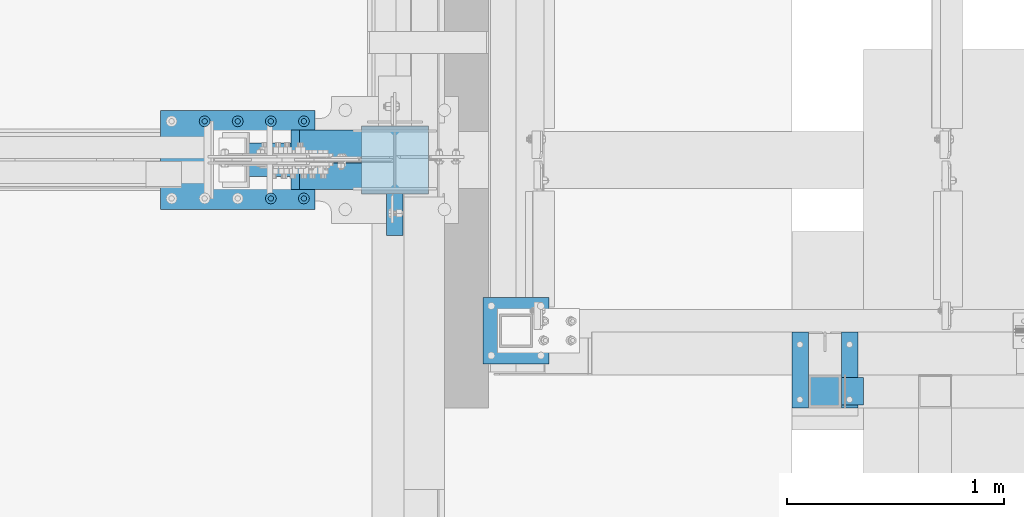
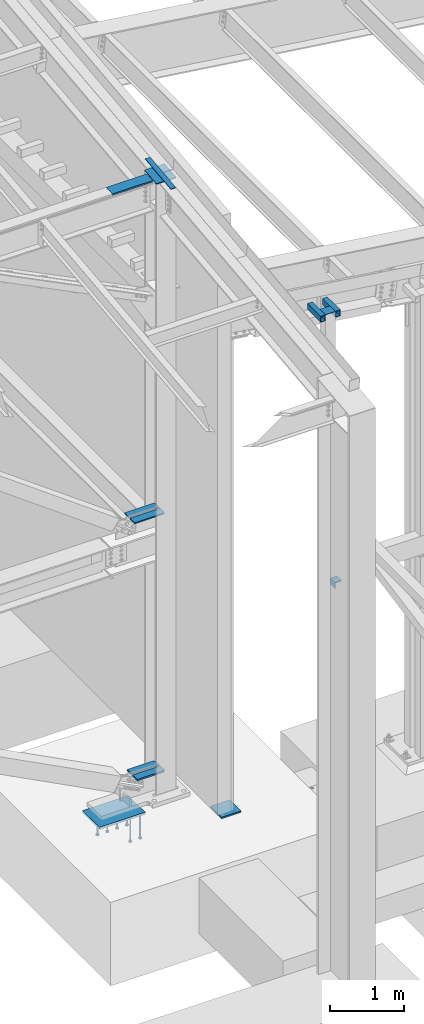
# One storey, part 819 of 1179: 19 beams, 10 elements without a shape of their own.
"""IFC2X3 building model written with IfcOpenShell, lengths in millimetres."""

from ifc_helpers import new_model, si_unit, frame, origin_with_axes, place, context, subcontext, project, spatial, faceted_brep, material, type_object, element, aggregate, save


model = new_model("IFC2X3")

# Units and contexts
model_context = context("Model", 3, precision=1e-05, world=origin_with_axes())
body_context = subcontext(model_context, "Body", "Model", "MODEL_VIEW")
ifc_project = project(units=[si_unit("LENGTHUNIT", "METRE", prefix="MILLI"), si_unit("AREAUNIT", "SQUARE_METRE"), si_unit("VOLUMEUNIT", "CUBIC_METRE"), si_unit("MASSUNIT", "GRAM", prefix="KILO"), si_unit("TIMEUNIT", "SECOND"), si_unit("PLANEANGLEUNIT", "RADIAN"), si_unit("SOLIDANGLEUNIT", "STERADIAN"), si_unit("THERMODYNAMICTEMPERATUREUNIT", "DEGREE_CELSIUS"), si_unit("LUMINOUSINTENSITYUNIT", "LUMEN")], contexts=[model_context])

# Site, building, storey
site_placement = place(None, origin_with_axes())
site = spatial("IfcSite", under=ifc_project, at=site_placement, CompositionType="ELEMENT")
building_placement = place(site_placement, origin_with_axes())
building = spatial("IfcBuilding", under=site, at=building_placement, Name="Undefined", CompositionType="ELEMENT")
storey_placement = place(building_placement, origin_with_axes())
storey = spatial("IfcBuildingStorey", under=building, at=storey_placement, Name="Undefined", CompositionType="ELEMENT", Elevation=0.0)

# Assembly, beam
assembly_1_placement = place(storey_placement, origin_with_axes())
assembly_1 = element("IfcElementAssembly", 1, at=assembly_1_placement, inside=storey, Name="BEAM", AssemblyPlace="NOTDEFINED", PredefinedType="RIGID_FRAME")
ifc_material_1 = material(Name="STEEL/A36")
beam_type_1 = type_object("IfcBeamType", PredefinedType="NOTDEFINED")
beam_1_placement = place(assembly_1_placement, frame((23828.3755023565, 5508.63433466315, 9826.91628432883), z_axis=(-1.0, 0.0, 0.0), x_axis=(0.0, 0.0, 1.0)))
beam_1 = element("IfcBeam", 2, at=beam_1_placement, type_object=beam_type_1, material=ifc_material_1, Name="BENT_PLATE", context=body_context, shape_type="Brep", body=[
    faceted_brep([(-2.72848410531878e-11, -4.76249999999982, -312.737499999999), (-2.72848410531878e-11, -4.76249999999982, 312.737499999999), (2.72848410531878e-11, 4.76249999999982, 312.737499999999), (2.72848410531878e-11, 4.76249999999982, -312.737499999999), (42.9704233723933, 4.76249999974698, 312.737499999999), (42.9704233723933, 4.76249999974698, -312.737499999999), (32.3091293486032, -4.7625000001899, -312.737499999999), (32.3091293486032, -4.7625000001899, 312.737499999999), (25.4000000054166, -150.812499999743, 312.737499999999), (25.4000000054166, -150.812499999743, -312.737499999999), (16.8901863939082, -141.287499999744, -312.737499999999), (16.8901863939082, -141.287499999744, 312.737499999999), (1.12777343019843e-08, -150.812499999746, 312.737499999999), (1.12777343019843e-08, -150.812499999746, -312.737499999999), (1.12777343019843e-08, -141.287499999747, 312.737499999999), (1.12777343019843e-08, -141.287499999747, -312.737499999999)], [[[0, 1, 2, 3]], [[3, 2, 4, 5]], [[1, 0, 6, 7]], [[5, 4, 8, 9]], [[7, 6, 10, 11]], [[9, 8, 12, 13]], [[8, 4, 2, 1, 7, 11, 14, 12]], [[11, 10, 15, 14]], [[10, 6, 0, 3, 5, 9, 13, 15]], [[14, 15, 13, 12]]]),
])
aggregate(assembly_1, [beam_1])

# Assembly, beams
assembly_2_placement = place(storey_placement, origin_with_axes())
assembly_2 = element("IfcElementAssembly", 3, at=assembly_2_placement, inside=storey, Name="COLUMN", AssemblyPlace="NOTDEFINED", PredefinedType="RIGID_FRAME")
beam_type_2 = type_object("IfcBeamType", PredefinedType="NOTDEFINED")
beam_2_placement = place(assembly_2_placement, frame((26289.0, 4292.6, 7569.0944715117), z_axis=(1.0, 0.0, 0.0), x_axis=(0.0, 1.0, 0.0)))
beam_2 = element("IfcBeam", 4, at=beam_2_placement, type_object=beam_type_2, material=ifc_material_1, Name="PLATE", context=body_context, shape_type="Brep", body=[
    faceted_brep([(-1.47792889038101e-12, 3.17500000000018, -76.1999999999953), (1.36424205265939e-12, 3.17500000000018, 76.1999999999953), (152.399999999989, 3.17500000000018, 76.200000000028), (152.399999999986, 3.17500000000018, -76.1999999999625), (1.36424205265939e-12, -3.17500000000018, 76.1999999999953), (152.399999999989, -3.17500000000018, 76.200000000028), (-1.47792889038101e-12, -3.17500000000018, -76.1999999999953), (152.399999999986, -3.17500000000018, -76.1999999999625)], [[[0, 1, 2, 3]], [[1, 4, 5, 2]], [[4, 6, 7, 5]], [[6, 0, 3, 7]], [[5, 7, 3, 2]], [[6, 4, 1, 0]]]),
])
beam_type_3 = type_object("IfcBeamType", Name="L4X4X3/8", PredefinedType="NOTDEFINED")
beam_3_placement = place(assembly_2_placement, frame((26416.0, 4305.3, 3060.7), z_axis=(1.0, 0.0, 0.0), x_axis=(0.0, 1.0, 0.0)))
beam_3 = element("IfcBeam", 5, at=beam_3_placement, type_object=beam_type_3, material=ifc_material_1, Name="ANGLE", ObjectType="L4X4X3/8", context=body_context, shape_type="Brep", body=[
    faceted_brep([(1.90993887372315e-11, 50.8000000000002, -50.8000000000002), (1.90993887372315e-11, 50.8000000000002, 50.8000000000002), (126.999999999993, 50.8000000000002, 50.7999999999993), (126.999999999993, 50.8000000000002, -50.7999999999993), (0.0, 41.2750000000015, 50.8000000000029), (126.999999999993, 41.2749999999996, 50.7999999999993), (0.0, 41.2750000000015, -41.2750000000015), (126.999999999993, 41.2749999999996, -41.2749999999996), (0.0, -50.7999999999993, -41.2750000000015), (126.999999999993, -50.8000000000002, -41.2749999999996), (-1.81898940354586e-11, -50.7999999999997, -50.8000000000002), (126.999999999993, -50.8000000000002, -50.7999999999993)], [[[0, 1, 2, 3]], [[1, 4, 5, 2]], [[4, 6, 7, 5]], [[6, 8, 9, 7]], [[8, 10, 11, 9]], [[10, 0, 3, 11]], [[5, 7, 9, 11, 3, 2]], [[10, 8, 6, 4, 1, 0]]]),
])

# Assembly, beam
assembly_3_placement = place(storey_placement, origin_with_axes())
assembly_3 = element("IfcElementAssembly", 6, at=assembly_3_placement, inside=storey, Name="PLATE", AssemblyPlace="NOTDEFINED", PredefinedType="RIGID_FRAME")
ifc_material_2 = material(Name="STEEL/A572-GR.50")
beam_type_4 = type_object("IfcBeamType", PredefinedType="NOTDEFINED")
beam_4_placement = place(assembly_3_placement, frame((24301.4300674267, 5361.781, 4369.97720905338), z_axis=(0.0, 1.0, 0.0), x_axis=(-1.0, 0.0, 0.0)))
beam_4 = element("IfcBeam", 7, at=beam_4_placement, type_object=beam_type_4, material=ifc_material_2, Name="PLATE", context=body_context, shape_type="Brep", body=[
    faceted_brep([(0.0, 9.52499999999964, -40.4814999999999), (22.2249999999985, 9.52499999999964, -62.7065000000002), (22.2249999999985, -9.52499999999964, -62.7065000000002), (0.0, -9.52499999999964, -40.4814999999999), (0.0, 9.52499999999964, 62.7065000000002), (471.877119336452, 9.52499999999964, 62.7065000000002), (471.877119336452, 9.52499999999964, -62.7065000000002), (0.0, -9.52499999999964, 62.7065000000002), (471.877119336452, -9.52499999999964, 62.7065000000002), (471.877119336452, -9.52499999999964, -62.7065000000002)], [[[0, 1, 2, 3]], [[4, 5, 6, 1, 0]], [[4, 7, 8, 5]], [[9, 8, 7, 3, 2]], [[6, 9, 2, 1]], [[8, 9, 6, 5]], [[7, 4, 0, 3]]]),
])
aggregate(assembly_3, [beam_4])

assembly_4_placement = place(storey_placement, origin_with_axes())
assembly_4 = element("IfcElementAssembly", 8, at=assembly_4_placement, inside=storey, Name="PLATE", AssemblyPlace="NOTDEFINED", PredefinedType="RIGID_FRAME")
beam_5_placement = place(assembly_4_placement, frame((24301.4300674267, 5509.419, 4369.97720905338), z_axis=(0.0, -1.0, 0.0), x_axis=(-1.0, 0.0, 0.0)))
beam_5 = element("IfcBeam", 9, at=beam_5_placement, type_object=beam_type_4, material=ifc_material_2, Name="PLATE", context=body_context, shape_type="Brep", body=[
    faceted_brep([(0.0, 9.52499999999964, -40.4814999999999), (22.2249999999985, 9.52499999999964, -62.7065000000002), (22.2249999999985, -9.52499999999964, -62.7065000000002), (0.0, -9.52499999999964, -40.4814999999999), (0.0, 9.52499999999964, 62.7065000000002), (471.877119336452, 9.52499999999964, 62.7065000000002), (471.877119336452, 9.52499999999964, -62.7065000000002), (0.0, -9.52499999999964, 62.7065000000002), (471.877119336452, -9.52499999999964, 62.7065000000002), (471.877119336452, -9.52499999999964, -62.7065000000002)], [[[0, 1, 2, 3]], [[4, 5, 6, 1, 0]], [[4, 7, 8, 5]], [[9, 8, 7, 3, 2]], [[6, 9, 2, 1]], [[8, 9, 6, 5]], [[7, 4, 0, 3]]]),
])
aggregate(assembly_4, [beam_5])

# Beam
ifc_material_3 = material()
beam_type_5 = type_object("IfcBeamType", Name="HSS4X3X5/16", PredefinedType="NOTDEFINED")
beam_6_placement = place(assembly_2_placement, frame((26403.3, 4292.6, 7521.4694715117), z_axis=(0.0, 0.0, 1.0), x_axis=(0.0, 1.0, 0.0)))
beam_6 = element("IfcBeam", 10, at=beam_6_placement, type_object=beam_type_5, material=ifc_material_3, Name="BEAM", ObjectType="HSS4X3X5/16", context=body_context, shape_type="Brep", body=[
    faceted_brep([(0.0, 30.1624999999985, -42.8625000000002), (0.0, -30.1624999999985, -42.8625000000002), (350.043746948247, -30.1624999999985, -42.8625000000002), (350.043746948247, 30.1624999999985, -42.8625000000002), (0.0, -30.1624999999985, 42.8625000000002), (350.043746948247, -30.1624999999985, 42.8625000000002), (0.0, 30.1624999999985, 42.8625000000002), (350.043746948247, 30.1624999999985, 42.8625000000002), (0.0, 38.0999999999985, -50.8000000000002), (1.45519152283669e-11, 38.1000000000004, 50.8000000000002), (350.043746948247, 38.0999999999985, 50.8000000000002), (350.043746948247, 38.0999999999985, -50.8000000000002), (0.0, -38.0999999999985, 50.8000000000002), (350.043746948247, -38.0999999999985, 50.8000000000002), (0.0, -38.0999999999985, -50.8000000000002), (350.043746948247, -38.0999999999985, -50.8000000000002)], [[[0, 1, 2, 3]], [[1, 4, 5, 2]], [[4, 6, 7, 5]], [[6, 0, 3, 7]], [[8, 9, 10, 11]], [[9, 12, 13, 10]], [[12, 14, 15, 13]], [[14, 8, 11, 15]], [[13, 15, 11, 10], [5, 7, 3, 2]], [[14, 12, 9, 8], [6, 4, 1, 0]]]),
])

beam_7_placement = place(assembly_2_placement, frame((26174.7, 4292.6, 7521.4694715117), z_axis=(0.0, 0.0, 1.0), x_axis=(0.0, 1.0, 0.0)))
beam_7 = element("IfcBeam", 11, at=beam_7_placement, type_object=beam_type_5, material=ifc_material_3, Name="BEAM", ObjectType="HSS4X3X5/16", context=body_context, shape_type="Brep", body=[
    faceted_brep([(0.0, 30.1624999999985, -42.8625000000002), (0.0, -30.1624999999985, -42.8625000000002), (350.043746948247, -30.1624999999985, -42.8625000000002), (350.043746948247, 30.1624999999985, -42.8625000000002), (0.0, -30.1624999999985, 42.8625000000002), (350.043746948247, -30.1624999999985, 42.8625000000002), (0.0, 30.1624999999985, 42.8625000000002), (350.043746948247, 30.1624999999985, 42.8625000000002), (0.0, 38.0999999999985, -50.8000000000002), (1.45519152283669e-11, 38.1000000000004, 50.8000000000002), (350.043746948247, 38.0999999999985, 50.8000000000002), (350.043746948247, 38.0999999999985, -50.8000000000002), (0.0, -38.0999999999985, 50.8000000000002), (350.043746948247, -38.0999999999985, 50.8000000000002), (0.0, -38.0999999999985, -50.8000000000002), (350.043746948247, -38.0999999999985, -50.8000000000002)], [[[0, 1, 2, 3]], [[1, 4, 5, 2]], [[4, 6, 7, 5]], [[6, 0, 3, 7]], [[8, 9, 10, 11]], [[9, 12, 13, 10]], [[12, 14, 15, 13]], [[14, 8, 11, 15]], [[13, 15, 11, 10], [5, 7, 3, 2]], [[14, 12, 9, 8], [6, 4, 1, 0]]]),
])

aggregate(assembly_2, [beam_2, beam_6, beam_7, beam_3])

# Assembly, beam
assembly_5_placement = place(storey_placement, origin_with_axes())
assembly_5 = element("IfcElementAssembly", 12, at=assembly_5_placement, inside=storey, Name="PLATE", AssemblyPlace="NOTDEFINED", PredefinedType="RIGID_FRAME")
beam_type_6 = type_object("IfcBeamType", PredefinedType="NOTDEFINED")
beam_8_placement = place(assembly_5_placement, frame((24301.45, 5511.006, 137.600649966597), z_axis=(0.0, -1.0, 0.0), x_axis=(-1.0, 0.0, 0.0)))
beam_8 = element("IfcBeam", 13, at=beam_8_placement, type_object=beam_type_6, material=ifc_material_2, Name="PLATE", context=body_context, shape_type="Brep", body=[
    faceted_brep([(21.43150038147, -12.7, -61.1189999999997), (0.0, -12.7, -39.6874996185288), (0.0, 12.7, -39.6874996185288), (21.43150038147, 12.7, -61.1189999999997), (0.0, 12.7, 61.1189999999988), (0.0, -12.7, 61.1189999999988), (433.411001535886, -12.7, 61.1189999999997), (433.411001535886, 12.7, 61.1189999999997), (433.411001535886, -12.7, -61.1189999999997), (433.411001535886, 12.7, -61.1189999999997)], [[[0, 1, 2, 3]], [[4, 5, 6, 7]], [[6, 8, 9, 7]], [[9, 8, 0, 3]], [[4, 7, 9, 3, 2]], [[5, 4, 2, 1]], [[8, 6, 5, 1, 0]]]),
])
aggregate(assembly_5, [beam_8])

assembly_6_placement = place(storey_placement, origin_with_axes())
assembly_6 = element("IfcElementAssembly", 14, at=assembly_6_placement, inside=storey, Name="PLATE", AssemblyPlace="NOTDEFINED", PredefinedType="RIGID_FRAME")
beam_9_placement = place(assembly_6_placement, frame((24301.45, 5360.194, 137.600649966597), z_axis=(0.0, 1.0, 0.0), x_axis=(-1.0, 0.0, 0.0)))
beam_9 = element("IfcBeam", 15, at=beam_9_placement, type_object=beam_type_6, material=ifc_material_2, Name="PLATE", context=body_context, shape_type="Brep", body=[
    faceted_brep([(21.43150038147, -12.7, -61.1189999999997), (0.0, -12.7, -39.6874996185288), (0.0, 12.7, -39.6874996185288), (21.43150038147, 12.7, -61.1189999999997), (0.0, 12.7, 61.1189999999988), (0.0, -12.7, 61.1189999999988), (433.411001535886, -12.7, 61.1189999999997), (433.411001535886, 12.7, 61.1189999999997), (433.411001535886, -12.7, -61.1189999999997), (433.411001535886, 12.7, -61.1189999999997)], [[[0, 1, 2, 3]], [[4, 5, 6, 7]], [[6, 8, 9, 7]], [[9, 8, 0, 3]], [[4, 7, 9, 3, 2]], [[5, 4, 2, 1]], [[8, 6, 5, 1, 0]]]),
])
aggregate(assembly_6, [beam_9])

assembly_7_placement = place(storey_placement, origin_with_axes())
assembly_7 = element("IfcElementAssembly", 16, at=assembly_7_placement, inside=storey, Name="PLATE", AssemblyPlace="NOTDEFINED", PredefinedType="RIGID_FRAME")
beam_type_7 = type_object("IfcBeamType", PredefinedType="NOTDEFINED")
beam_10_placement = place(assembly_7_placement, frame((24307.8, 5088.52709745709, 9826.67041081512), z_axis=(-1.0, 0.0, 0.0), x_axis=(0.0, 0.993676357192036, 0.112282221021699)))
beam_10 = element("IfcBeam", 17, at=beam_10_placement, type_object=beam_type_7, material=ifc_material_2, Name="PLATE", context=body_context, shape_type="Brep", body=[
    faceted_brep([(1.81898940354586e-12, 4.76249999999891, -38.0999999999985), (0.0, 4.76250000000073, 38.0999999999985), (697.487007013381, 4.76249999976426, 38.0999999999985), (697.487007013381, 4.76249999976426, -38.0999999999985), (0.0, -4.76250000000073, 38.0999999999985), (697.487007013379, -4.7625000002372, 38.0999999999985), (-9.09494701772928e-13, -4.76250000000073, -38.0999999999985), (697.487007013379, -4.7625000002372, -38.0999999999985)], [[[0, 1, 2, 3]], [[1, 4, 5, 2]], [[4, 6, 7, 5]], [[6, 0, 3, 7]], [[5, 7, 3, 2]], [[6, 4, 1, 0]]]),
])
aggregate(assembly_7, [beam_10])

assembly_8_placement = place(storey_placement, origin_with_axes())
assembly_8 = element("IfcElementAssembly", 18, at=assembly_8_placement, inside=storey, Name="COLUMN", AssemblyPlace="NOTDEFINED", PredefinedType="RIGID_FRAME")
beam_type_8 = type_object("IfcBeamType", PredefinedType="NOTDEFINED")
beam_11_placement = place(assembly_8_placement, frame((24307.8, 5593.47599534686, 9872.55415549832), z_axis=(1.0, 0.0, 0.0), x_axis=(0.0, -0.993676357192036, -0.112282221021698)))
beam_11 = element("IfcBeam", 19, at=beam_11_placement, type_object=beam_type_8, material=ifc_material_1, Name="PLATE", context=body_context, shape_type="Brep", body=[
    faceted_brep([(1.43506562315542, 6.34999999999854, -153.987499999999), (1.43506562315542, 6.34999999999854, 153.987499999999), (317.7609155726, 6.34999999998217, 153.987499999999), (317.7609155726, 6.34999999998217, -153.987499999999), (8.43101588543504e-10, -6.350000000004, 153.987499999999), (316.325849950289, -6.35000000002219, 153.987499999999), (8.43101588543504e-10, -6.350000000004, -153.987499999999), (316.325849950289, -6.35000000002219, -153.987499999999)], [[[0, 1, 2, 3]], [[1, 4, 5, 2]], [[4, 6, 7, 5]], [[6, 0, 3, 7]], [[5, 7, 3, 2]], [[6, 4, 1, 0]]]),
])
aggregate(assembly_8, [beam_11])

assembly_9_placement = place(storey_placement, origin_with_axes())
assembly_9 = element("IfcElementAssembly", 20, at=assembly_9_placement, inside=storey, Name="COLUMN", AssemblyPlace="NOTDEFINED", PredefinedType="RIGID_FRAME")
beam_type_9 = type_object("IfcBeamType", PredefinedType="NOTDEFINED")
beam_12_placement = place(assembly_9_placement, frame((24714.2, 4648.2, -292.1), z_axis=(0.0, 1.0, 0.0), x_axis=(1.0, 0.0, 0.0)))
beam_12 = element("IfcBeam", 21, at=beam_12_placement, type_object=beam_type_9, material=ifc_material_2, context=body_context, shape_type="Brep", body=[
    faceted_brep([(-7.27595761418343e-12, 12.7, -152.400000000011), (7.27595761418343e-12, 12.7, 152.400000000011), (304.800000000494, 12.7, 152.400000000071), (304.800000000479, 12.7, -152.39999999995), (7.27595761418343e-12, -12.7, 152.400000000011), (304.800000000494, -12.7, 152.400000000071), (-7.27595761418343e-12, -12.7, -152.400000000011), (304.800000000479, -12.7, -152.39999999995)], [[[0, 1, 2, 3]], [[1, 4, 5, 2]], [[4, 6, 7, 5]], [[6, 0, 3, 7]], [[5, 7, 3, 2]], [[6, 4, 1, 0]]]),
])
aggregate(assembly_9, [beam_12])

# Assembly, beams
assembly_10_placement = place(storey_placement, origin_with_axes())
assembly_10 = element("IfcElementAssembly", 22, at=assembly_10_placement, inside=storey, Name="EMBED_PLATE", AssemblyPlace="NOTDEFINED", PredefinedType="RIGID_FRAME")
ifc_material_4 = material(Name="STEEL/A108")
beam_type_10 = type_object("IfcBeamType", Name="STUD_1-DIA", PredefinedType="NOTDEFINED")
beam_13_placement = place(assembly_10_placement, frame((23888.7, 5257.8, -393.700000000001), z_axis=(-1.0, 0.0, 0.0), x_axis=(0.0, 0.0, -1.0)))
beam_13 = element("IfcBeam", 23, at=beam_13_placement, type_object=beam_type_10, material=ifc_material_4, Name="STUD", ObjectType="STUD_1-DIA", context=body_context, shape_type="Brep", body=[
    faceted_brep([(0.0, -12.7, 0.0), (0.0, -11.0, -6.34999990463257), (382.016, -11.0, -6.34999990463257), (382.016, -12.6999998092651, 0.0), (0.0, -6.34999990463257, -11.0), (382.016, -6.34999990463257, -11.0), (0.0, 0.0, -12.6999998092651), (382.016, 0.0, -12.6999998092651), (0.0, 6.34999990463257, -11.0), (382.016, 6.34999990463257, -11.0), (0.0, 11.0, -6.34999990463257), (382.016, 11.0, -6.34999990463257), (0.0, 12.7, 0.0), (382.016, 12.6999998092651, 0.0), (0.0, 11.0, 6.34999990463257), (382.016, 11.0, 6.34999990463257), (0.0, 6.34999990463257, 11.0), (382.016, 6.34999990463257, 11.0), (0.0, 0.0, 12.6999998092651), (382.016, 0.0, 12.6999998092651), (0.0, -6.34999990463257, 11.0), (382.016, -6.34999990463257, 11.0), (0.0, -11.0, 6.34999990463257), (382.016, -11.0, 6.34999990463257), (386.08, -22.0, -12.6999998092651), (386.08, -25.3999996185303, 0.0), (386.08, -12.6999998092651, -22.0), (386.08, 0.0, -25.3999996185303), (386.08, 12.6999998092651, -22.0), (386.08, 22.0, -12.6999998092651), (386.08, 25.3999996185303, 0.0), (386.08, 22.0, 12.6999998092651), (386.08, 12.6999998092651, 22.0), (386.08, 0.0, 25.3999996185303), (386.08, -12.6999998092651, 22.0), (386.08, -22.0, 12.6999998092651), (406.4, -22.0, -12.6999998092651), (406.4, -25.3999996185303, 0.0), (406.4, -12.6999998092651, -22.0), (406.4, 0.0, -25.3999996185303), (406.4, 12.6999998092651, -22.0), (406.4, 22.0, -12.6999998092651), (406.4, 25.3999996185303, 0.0), (406.4, 22.0, 12.6999998092651), (406.4, 12.6999998092651, 22.0), (406.4, 0.0, 25.3999996185303), (406.4, -12.6999998092651, 22.0), (406.4, -22.0, 12.6999998092651)], [[[0, 1, 2, 3]], [[1, 4, 5, 2]], [[4, 6, 7, 5]], [[6, 8, 9, 7]], [[8, 10, 11, 9]], [[10, 12, 13, 11]], [[12, 14, 15, 13]], [[14, 16, 17, 15]], [[16, 18, 19, 17]], [[18, 20, 21, 19]], [[20, 22, 23, 21]], [[22, 0, 3, 23]], [[22, 20, 18, 16, 14, 12, 10, 8, 6, 4, 1, 0]], [[3, 2, 24, 25]], [[2, 5, 26, 24]], [[5, 7, 27, 26]], [[7, 9, 28, 27]], [[9, 11, 29, 28]], [[11, 13, 30, 29]], [[13, 15, 31, 30]], [[15, 17, 32, 31]], [[17, 19, 33, 32]], [[19, 21, 34, 33]], [[21, 23, 35, 34]], [[23, 3, 25, 35]], [[25, 24, 36, 37]], [[24, 26, 38, 36]], [[26, 27, 39, 38]], [[27, 28, 40, 39]], [[28, 29, 41, 40]], [[29, 30, 42, 41]], [[30, 31, 43, 42]], [[31, 32, 44, 43]], [[32, 33, 45, 44]], [[33, 34, 46, 45]], [[34, 35, 47, 46]], [[35, 25, 37, 47]], [[38, 39, 40, 41, 42, 43, 44, 45, 46, 47, 37, 36]]]),
])
beam_14_placement = place(assembly_10_placement, frame((23888.7, 5613.4, -393.700000000001), z_axis=(-1.0, 0.0, 0.0), x_axis=(0.0, 0.0, -1.0)))
beam_14 = element("IfcBeam", 24, at=beam_14_placement, type_object=beam_type_10, material=ifc_material_4, Name="STUD", ObjectType="STUD_1-DIA", context=body_context, shape_type="Brep", body=[
    faceted_brep([(0.0, -12.7, 0.0), (0.0, -11.0, -6.34999990463257), (382.016, -11.0, -6.34999990463257), (382.016, -12.6999998092651, 0.0), (0.0, -6.34999990463257, -11.0), (382.016, -6.34999990463257, -11.0), (0.0, 0.0, -12.6999998092651), (382.016, 0.0, -12.6999998092651), (0.0, 6.34999990463257, -11.0), (382.016, 6.34999990463257, -11.0), (0.0, 11.0, -6.34999990463257), (382.016, 11.0, -6.34999990463257), (0.0, 12.7, 0.0), (382.016, 12.6999998092651, 0.0), (0.0, 11.0, 6.34999990463257), (382.016, 11.0, 6.34999990463257), (0.0, 6.34999990463257, 11.0), (382.016, 6.34999990463257, 11.0), (0.0, 0.0, 12.6999998092651), (382.016, 0.0, 12.6999998092651), (0.0, -6.34999990463257, 11.0), (382.016, -6.34999990463257, 11.0), (0.0, -11.0, 6.34999990463257), (382.016, -11.0, 6.34999990463257), (386.08, -22.0, -12.6999998092651), (386.08, -25.3999996185303, 0.0), (386.08, -12.6999998092651, -22.0), (386.08, 0.0, -25.3999996185303), (386.08, 12.6999998092651, -22.0), (386.08, 22.0, -12.6999998092651), (386.08, 25.3999996185303, 0.0), (386.08, 22.0, 12.6999998092651), (386.08, 12.6999998092651, 22.0), (386.08, 0.0, 25.3999996185303), (386.08, -12.6999998092651, 22.0), (386.08, -22.0, 12.6999998092651), (406.4, -22.0, -12.6999998092651), (406.4, -25.3999996185303, 0.0), (406.4, -12.6999998092651, -22.0), (406.4, 0.0, -25.3999996185303), (406.4, 12.6999998092651, -22.0), (406.4, 22.0, -12.6999998092651), (406.4, 25.3999996185303, 0.0), (406.4, 22.0, 12.6999998092651), (406.4, 12.6999998092651, 22.0), (406.4, 0.0, 25.3999996185303), (406.4, -12.6999998092651, 22.0), (406.4, -22.0, 12.6999998092651)], [[[0, 1, 2, 3]], [[1, 4, 5, 2]], [[4, 6, 7, 5]], [[6, 8, 9, 7]], [[8, 10, 11, 9]], [[10, 12, 13, 11]], [[12, 14, 15, 13]], [[14, 16, 17, 15]], [[16, 18, 19, 17]], [[18, 20, 21, 19]], [[20, 22, 23, 21]], [[22, 0, 3, 23]], [[22, 20, 18, 16, 14, 12, 10, 8, 6, 4, 1, 0]], [[3, 2, 24, 25]], [[2, 5, 26, 24]], [[5, 7, 27, 26]], [[7, 9, 28, 27]], [[9, 11, 29, 28]], [[11, 13, 30, 29]], [[13, 15, 31, 30]], [[15, 17, 32, 31]], [[17, 19, 33, 32]], [[19, 21, 34, 33]], [[21, 23, 35, 34]], [[23, 3, 25, 35]], [[25, 24, 36, 37]], [[24, 26, 38, 36]], [[26, 27, 39, 38]], [[27, 28, 40, 39]], [[28, 29, 41, 40]], [[29, 30, 42, 41]], [[30, 31, 43, 42]], [[31, 32, 44, 43]], [[32, 33, 45, 44]], [[33, 34, 46, 45]], [[34, 35, 47, 46]], [[35, 25, 37, 47]], [[38, 39, 40, 41, 42, 43, 44, 45, 46, 47, 37, 36]]]),
])
beam_15_placement = place(assembly_10_placement, frame((23736.3, 5257.8, -393.700000000001), z_axis=(-1.0, 0.0, 0.0), x_axis=(0.0, 0.0, -1.0)))
beam_15 = element("IfcBeam", 25, at=beam_15_placement, type_object=beam_type_10, material=ifc_material_4, Name="STUD", ObjectType="STUD_1-DIA", context=body_context, shape_type="Brep", body=[
    faceted_brep([(0.0, -12.7, 0.0), (0.0, -11.0, -6.34999990463257), (382.016, -11.0, -6.34999990463257), (382.016, -12.6999998092651, 0.0), (0.0, -6.34999990463257, -11.0), (382.016, -6.34999990463257, -11.0), (0.0, 0.0, -12.6999998092651), (382.016, 0.0, -12.6999998092651), (0.0, 6.34999990463257, -11.0), (382.016, 6.34999990463257, -11.0), (0.0, 11.0, -6.34999990463257), (382.016, 11.0, -6.34999990463257), (0.0, 12.7, 0.0), (382.016, 12.6999998092651, 0.0), (0.0, 11.0, 6.34999990463257), (382.016, 11.0, 6.34999990463257), (0.0, 6.34999990463257, 11.0), (382.016, 6.34999990463257, 11.0), (0.0, 0.0, 12.6999998092651), (382.016, 0.0, 12.6999998092651), (0.0, -6.34999990463257, 11.0), (382.016, -6.34999990463257, 11.0), (0.0, -11.0, 6.34999990463257), (382.016, -11.0, 6.34999990463257), (386.08, -22.0, -12.6999998092651), (386.08, -25.3999996185303, 0.0), (386.08, -12.6999998092651, -22.0), (386.08, 0.0, -25.3999996185303), (386.08, 12.6999998092651, -22.0), (386.08, 22.0, -12.6999998092651), (386.08, 25.3999996185303, 0.0), (386.08, 22.0, 12.6999998092651), (386.08, 12.6999998092651, 22.0), (386.08, 0.0, 25.3999996185303), (386.08, -12.6999998092651, 22.0), (386.08, -22.0, 12.6999998092651), (406.4, -22.0, -12.6999998092651), (406.4, -25.3999996185303, 0.0), (406.4, -12.6999998092651, -22.0), (406.4, 0.0, -25.3999996185303), (406.4, 12.6999998092651, -22.0), (406.4, 22.0, -12.6999998092651), (406.4, 25.3999996185303, 0.0), (406.4, 22.0, 12.6999998092651), (406.4, 12.6999998092651, 22.0), (406.4, 0.0, 25.3999996185303), (406.4, -12.6999998092651, 22.0), (406.4, -22.0, 12.6999998092651)], [[[0, 1, 2, 3]], [[1, 4, 5, 2]], [[4, 6, 7, 5]], [[6, 8, 9, 7]], [[8, 10, 11, 9]], [[10, 12, 13, 11]], [[12, 14, 15, 13]], [[14, 16, 17, 15]], [[16, 18, 19, 17]], [[18, 20, 21, 19]], [[20, 22, 23, 21]], [[22, 0, 3, 23]], [[22, 20, 18, 16, 14, 12, 10, 8, 6, 4, 1, 0]], [[3, 2, 24, 25]], [[2, 5, 26, 24]], [[5, 7, 27, 26]], [[7, 9, 28, 27]], [[9, 11, 29, 28]], [[11, 13, 30, 29]], [[13, 15, 31, 30]], [[15, 17, 32, 31]], [[17, 19, 33, 32]], [[19, 21, 34, 33]], [[21, 23, 35, 34]], [[23, 3, 25, 35]], [[25, 24, 36, 37]], [[24, 26, 38, 36]], [[26, 27, 39, 38]], [[27, 28, 40, 39]], [[28, 29, 41, 40]], [[29, 30, 42, 41]], [[30, 31, 43, 42]], [[31, 32, 44, 43]], [[32, 33, 45, 44]], [[33, 34, 46, 45]], [[34, 35, 47, 46]], [[35, 25, 37, 47]], [[38, 39, 40, 41, 42, 43, 44, 45, 46, 47, 37, 36]]]),
])
beam_16_placement = place(assembly_10_placement, frame((23431.5, 5613.4, -393.700000000001), z_axis=(-1.0, 0.0, 0.0), x_axis=(0.0, 0.0, -1.0)))
beam_16 = element("IfcBeam", 26, at=beam_16_placement, type_object=beam_type_10, material=ifc_material_4, Name="STUD", ObjectType="STUD_1-DIA", context=body_context, shape_type="Brep", body=[
    faceted_brep([(0.0, -12.7, 0.0), (0.0, -11.0, -6.34999990463257), (382.016, -11.0, -6.34999990463257), (382.016, -12.6999998092651, 0.0), (0.0, -6.34999990463257, -11.0), (382.016, -6.34999990463257, -11.0), (0.0, 0.0, -12.6999998092651), (382.016, 0.0, -12.6999998092651), (0.0, 6.34999990463257, -11.0), (382.016, 6.34999990463257, -11.0), (0.0, 11.0, -6.34999990463257), (382.016, 11.0, -6.34999990463257), (0.0, 12.7, 0.0), (382.016, 12.6999998092651, 0.0), (0.0, 11.0, 6.34999990463257), (382.016, 11.0, 6.34999990463257), (0.0, 6.34999990463257, 11.0), (382.016, 6.34999990463257, 11.0), (0.0, 0.0, 12.6999998092651), (382.016, 0.0, 12.6999998092651), (0.0, -6.34999990463257, 11.0), (382.016, -6.34999990463257, 11.0), (0.0, -11.0, 6.34999990463257), (382.016, -11.0, 6.34999990463257), (386.08, -22.0, -12.6999998092651), (386.08, -25.3999996185303, 0.0), (386.08, -12.6999998092651, -22.0), (386.08, 0.0, -25.3999996185303), (386.08, 12.6999998092651, -22.0), (386.08, 22.0, -12.6999998092651), (386.08, 25.3999996185303, 0.0), (386.08, 22.0, 12.6999998092651), (386.08, 12.6999998092651, 22.0), (386.08, 0.0, 25.3999996185303), (386.08, -12.6999998092651, 22.0), (386.08, -22.0, 12.6999998092651), (406.4, -22.0, -12.6999998092651), (406.4, -25.3999996185303, 0.0), (406.4, -12.6999998092651, -22.0), (406.4, 0.0, -25.3999996185303), (406.4, 12.6999998092651, -22.0), (406.4, 22.0, -12.6999998092651), (406.4, 25.3999996185303, 0.0), (406.4, 22.0, 12.6999998092651), (406.4, 12.6999998092651, 22.0), (406.4, 0.0, 25.3999996185303), (406.4, -12.6999998092651, 22.0), (406.4, -22.0, 12.6999998092651)], [[[0, 1, 2, 3]], [[1, 4, 5, 2]], [[4, 6, 7, 5]], [[6, 8, 9, 7]], [[8, 10, 11, 9]], [[10, 12, 13, 11]], [[12, 14, 15, 13]], [[14, 16, 17, 15]], [[16, 18, 19, 17]], [[18, 20, 21, 19]], [[20, 22, 23, 21]], [[22, 0, 3, 23]], [[22, 20, 18, 16, 14, 12, 10, 8, 6, 4, 1, 0]], [[3, 2, 24, 25]], [[2, 5, 26, 24]], [[5, 7, 27, 26]], [[7, 9, 28, 27]], [[9, 11, 29, 28]], [[11, 13, 30, 29]], [[13, 15, 31, 30]], [[15, 17, 32, 31]], [[17, 19, 33, 32]], [[19, 21, 34, 33]], [[21, 23, 35, 34]], [[23, 3, 25, 35]], [[25, 24, 36, 37]], [[24, 26, 38, 36]], [[26, 27, 39, 38]], [[27, 28, 40, 39]], [[28, 29, 41, 40]], [[29, 30, 42, 41]], [[30, 31, 43, 42]], [[31, 32, 44, 43]], [[32, 33, 45, 44]], [[33, 34, 46, 45]], [[34, 35, 47, 46]], [[35, 25, 37, 47]], [[38, 39, 40, 41, 42, 43, 44, 45, 46, 47, 37, 36]]]),
])
beam_17_placement = place(assembly_10_placement, frame((23583.9, 5613.4, -393.700000000001), z_axis=(-1.0, 0.0, 0.0), x_axis=(0.0, 0.0, -1.0)))
beam_17 = element("IfcBeam", 27, at=beam_17_placement, type_object=beam_type_10, material=ifc_material_4, Name="STUD", ObjectType="STUD_1-DIA", context=body_context, shape_type="Brep", body=[
    faceted_brep([(0.0, -12.7, 0.0), (0.0, -11.0, -6.34999990463257), (382.016, -11.0, -6.34999990463257), (382.016, -12.6999998092651, 0.0), (0.0, -6.34999990463257, -11.0), (382.016, -6.34999990463257, -11.0), (0.0, 0.0, -12.6999998092651), (382.016, 0.0, -12.6999998092651), (0.0, 6.34999990463257, -11.0), (382.016, 6.34999990463257, -11.0), (0.0, 11.0, -6.34999990463257), (382.016, 11.0, -6.34999990463257), (0.0, 12.7, 0.0), (382.016, 12.6999998092651, 0.0), (0.0, 11.0, 6.34999990463257), (382.016, 11.0, 6.34999990463257), (0.0, 6.34999990463257, 11.0), (382.016, 6.34999990463257, 11.0), (0.0, 0.0, 12.6999998092651), (382.016, 0.0, 12.6999998092651), (0.0, -6.34999990463257, 11.0), (382.016, -6.34999990463257, 11.0), (0.0, -11.0, 6.34999990463257), (382.016, -11.0, 6.34999990463257), (386.08, -22.0, -12.6999998092651), (386.08, -25.3999996185303, 0.0), (386.08, -12.6999998092651, -22.0), (386.08, 0.0, -25.3999996185303), (386.08, 12.6999998092651, -22.0), (386.08, 22.0, -12.6999998092651), (386.08, 25.3999996185303, 0.0), (386.08, 22.0, 12.6999998092651), (386.08, 12.6999998092651, 22.0), (386.08, 0.0, 25.3999996185303), (386.08, -12.6999998092651, 22.0), (386.08, -22.0, 12.6999998092651), (406.4, -22.0, -12.6999998092651), (406.4, -25.3999996185303, 0.0), (406.4, -12.6999998092651, -22.0), (406.4, 0.0, -25.3999996185303), (406.4, 12.6999998092651, -22.0), (406.4, 22.0, -12.6999998092651), (406.4, 25.3999996185303, 0.0), (406.4, 22.0, 12.6999998092651), (406.4, 12.6999998092651, 22.0), (406.4, 0.0, 25.3999996185303), (406.4, -12.6999998092651, 22.0), (406.4, -22.0, 12.6999998092651)], [[[0, 1, 2, 3]], [[1, 4, 5, 2]], [[4, 6, 7, 5]], [[6, 8, 9, 7]], [[8, 10, 11, 9]], [[10, 12, 13, 11]], [[12, 14, 15, 13]], [[14, 16, 17, 15]], [[16, 18, 19, 17]], [[18, 20, 21, 19]], [[20, 22, 23, 21]], [[22, 0, 3, 23]], [[22, 20, 18, 16, 14, 12, 10, 8, 6, 4, 1, 0]], [[3, 2, 24, 25]], [[2, 5, 26, 24]], [[5, 7, 27, 26]], [[7, 9, 28, 27]], [[9, 11, 29, 28]], [[11, 13, 30, 29]], [[13, 15, 31, 30]], [[15, 17, 32, 31]], [[17, 19, 33, 32]], [[19, 21, 34, 33]], [[21, 23, 35, 34]], [[23, 3, 25, 35]], [[25, 24, 36, 37]], [[24, 26, 38, 36]], [[26, 27, 39, 38]], [[27, 28, 40, 39]], [[28, 29, 41, 40]], [[29, 30, 42, 41]], [[30, 31, 43, 42]], [[31, 32, 44, 43]], [[32, 33, 45, 44]], [[33, 34, 46, 45]], [[34, 35, 47, 46]], [[35, 25, 37, 47]], [[38, 39, 40, 41, 42, 43, 44, 45, 46, 47, 37, 36]]]),
])
beam_18_placement = place(assembly_10_placement, frame((23736.3, 5613.4, -393.700000000001), z_axis=(-1.0, 0.0, 0.0), x_axis=(0.0, 0.0, -1.0)))
beam_18 = element("IfcBeam", 28, at=beam_18_placement, type_object=beam_type_10, material=ifc_material_4, Name="STUD", ObjectType="STUD_1-DIA", context=body_context, shape_type="Brep", body=[
    faceted_brep([(0.0, -12.7, 0.0), (0.0, -11.0, -6.34999990463257), (382.016, -11.0, -6.34999990463257), (382.016, -12.6999998092651, 0.0), (0.0, -6.34999990463257, -11.0), (382.016, -6.34999990463257, -11.0), (0.0, 0.0, -12.6999998092651), (382.016, 0.0, -12.6999998092651), (0.0, 6.34999990463257, -11.0), (382.016, 6.34999990463257, -11.0), (0.0, 11.0, -6.34999990463257), (382.016, 11.0, -6.34999990463257), (0.0, 12.7, 0.0), (382.016, 12.6999998092651, 0.0), (0.0, 11.0, 6.34999990463257), (382.016, 11.0, 6.34999990463257), (0.0, 6.34999990463257, 11.0), (382.016, 6.34999990463257, 11.0), (0.0, 0.0, 12.6999998092651), (382.016, 0.0, 12.6999998092651), (0.0, -6.34999990463257, 11.0), (382.016, -6.34999990463257, 11.0), (0.0, -11.0, 6.34999990463257), (382.016, -11.0, 6.34999990463257), (386.08, -22.0, -12.6999998092651), (386.08, -25.3999996185303, 0.0), (386.08, -12.6999998092651, -22.0), (386.08, 0.0, -25.3999996185303), (386.08, 12.6999998092651, -22.0), (386.08, 22.0, -12.6999998092651), (386.08, 25.3999996185303, 0.0), (386.08, 22.0, 12.6999998092651), (386.08, 12.6999998092651, 22.0), (386.08, 0.0, 25.3999996185303), (386.08, -12.6999998092651, 22.0), (386.08, -22.0, 12.6999998092651), (406.4, -22.0, -12.6999998092651), (406.4, -25.3999996185303, 0.0), (406.4, -12.6999998092651, -22.0), (406.4, 0.0, -25.3999996185303), (406.4, 12.6999998092651, -22.0), (406.4, 22.0, -12.6999998092651), (406.4, 25.3999996185303, 0.0), (406.4, 22.0, 12.6999998092651), (406.4, 12.6999998092651, 22.0), (406.4, 0.0, 25.3999996185303), (406.4, -12.6999998092651, 22.0), (406.4, -22.0, 12.6999998092651)], [[[0, 1, 2, 3]], [[1, 4, 5, 2]], [[4, 6, 7, 5]], [[6, 8, 9, 7]], [[8, 10, 11, 9]], [[10, 12, 13, 11]], [[12, 14, 15, 13]], [[14, 16, 17, 15]], [[16, 18, 19, 17]], [[18, 20, 21, 19]], [[20, 22, 23, 21]], [[22, 0, 3, 23]], [[22, 20, 18, 16, 14, 12, 10, 8, 6, 4, 1, 0]], [[3, 2, 24, 25]], [[2, 5, 26, 24]], [[5, 7, 27, 26]], [[7, 9, 28, 27]], [[9, 11, 29, 28]], [[11, 13, 30, 29]], [[13, 15, 31, 30]], [[15, 17, 32, 31]], [[17, 19, 33, 32]], [[19, 21, 34, 33]], [[21, 23, 35, 34]], [[23, 3, 25, 35]], [[25, 24, 36, 37]], [[24, 26, 38, 36]], [[26, 27, 39, 38]], [[27, 28, 40, 39]], [[28, 29, 41, 40]], [[29, 30, 42, 41]], [[30, 31, 43, 42]], [[31, 32, 44, 43]], [[32, 33, 45, 44]], [[33, 34, 46, 45]], [[34, 35, 47, 46]], [[35, 25, 37, 47]], [[38, 39, 40, 41, 42, 43, 44, 45, 46, 47, 37, 36]]]),
])
beam_type_11 = type_object("IfcBeamType", PredefinedType="NOTDEFINED")
beam_19_placement = place(assembly_10_placement, frame((23939.5, 5435.6, -374.65), z_axis=(0.0, -1.0, 0.0), x_axis=(-1.0, 0.0, 0.0)))
beam_19 = element("IfcBeam", 29, at=beam_19_placement, type_object=beam_type_11, material=ifc_material_2, Name="EMBED_PLATE", context=body_context, shape_type="Brep", body=[
    faceted_brep([(0.0, 19.05, -228.6), (0.0, 19.05, 228.6), (711.200000000001, 19.05, 228.599999999999), (711.200000000001, 19.05, -228.599999999999), (0.0, -19.05, 228.6), (711.200000000001, -19.05, 228.599999999999), (0.0, -19.05, -228.6), (711.200000000001, -19.05, -228.599999999999)], [[[0, 1, 2, 3]], [[1, 4, 5, 2]], [[4, 6, 7, 5]], [[6, 0, 3, 7]], [[5, 7, 3, 2]], [[6, 4, 1, 0]]]),
])
aggregate(assembly_10, [beam_13, beam_14, beam_15, beam_16, beam_17, beam_18, beam_19])

save(model, "model.ifc")
